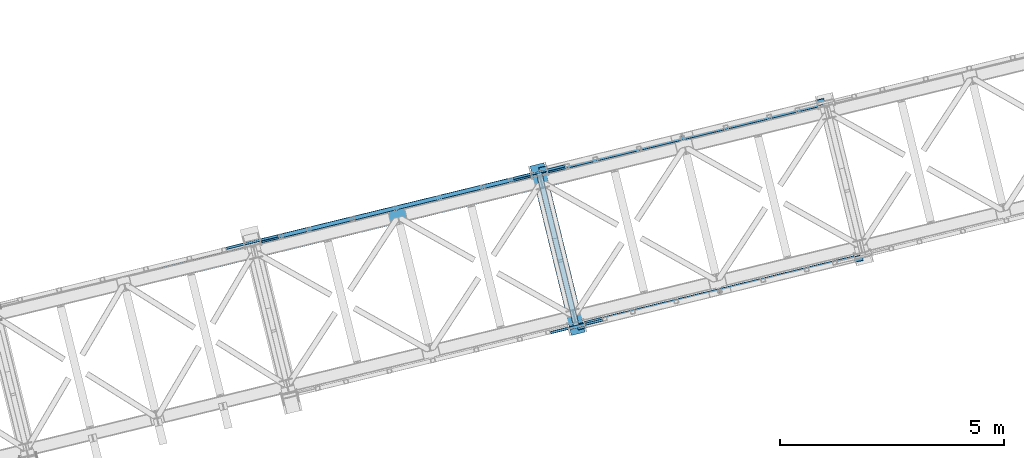
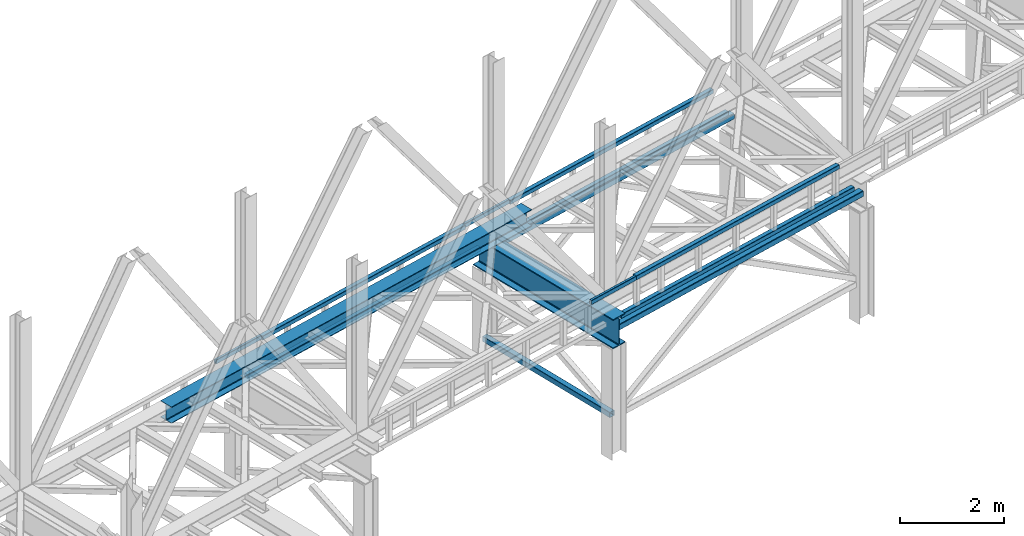
# One storey, part 16 of 93: 11 beams, 3 members.
"""IFC4 building model written with IfcOpenShell, lengths in millimetres."""

from ifc_helpers import new_model, entity, si_unit, converted_unit, derived_unit, direction, frame, origin, place, context, subcontext, project, spatial, indexed_curve, outline, extrude, material, type_object, element, save


model = new_model("IFC4")

# Units and contexts
model_context = context("Model", 3, precision=0.01, world=origin(), true_north=direction((6.12303176911189e-17, 1.0)))
plan_context = context("Plan", 3, precision=0.01, world=origin(), true_north=direction((6.12303176911189e-17, 1.0)))
body_context = subcontext(model_context, "Body", "Model", "MODEL_VIEW")
ifc_project = project(units=[si_unit("LENGTHUNIT", "METRE", prefix="MILLI"), si_unit("AREAUNIT", "SQUARE_METRE"), si_unit("VOLUMEUNIT", "CUBIC_METRE"), converted_unit("PLANEANGLEUNIT", "DEGREE", entity("IfcRatioMeasure", 0.0174532925199433), si_unit("PLANEANGLEUNIT", "RADIAN"), dimensions=[0, 0, 0, 0, 0, 0, 0]), si_unit("MASSUNIT", "GRAM", prefix="KILO"), derived_unit("MASSDENSITYUNIT", [(si_unit("MASSUNIT", "GRAM", prefix="KILO"), 1), (si_unit("LENGTHUNIT", "METRE"), -3)]), derived_unit("MOMENTOFINERTIAUNIT", [(si_unit("LENGTHUNIT", "METRE"), 4)]), si_unit("TIMEUNIT", "SECOND"), si_unit("FREQUENCYUNIT", "HERTZ"), si_unit("THERMODYNAMICTEMPERATUREUNIT", "DEGREE_CELSIUS"), derived_unit("THERMALTRANSMITTANCEUNIT", [(si_unit("MASSUNIT", "GRAM", prefix="KILO"), 1), (si_unit("THERMODYNAMICTEMPERATUREUNIT", "KELVIN"), -1), (si_unit("TIMEUNIT", "SECOND"), -3)]), derived_unit("VOLUMETRICFLOWRATEUNIT", [(si_unit("LENGTHUNIT", "METRE"), 3), (si_unit("TIMEUNIT", "SECOND"), -1)]), derived_unit("MASSFLOWRATEUNIT", [(si_unit("MASSUNIT", "GRAM", prefix="KILO"), 1), (si_unit("TIMEUNIT", "SECOND"), -1)]), derived_unit("ROTATIONALFREQUENCYUNIT", [(si_unit("TIMEUNIT", "SECOND"), -1)]), si_unit("ELECTRICCURRENTUNIT", "AMPERE"), si_unit("ELECTRICVOLTAGEUNIT", "VOLT"), si_unit("POWERUNIT", "WATT"), si_unit("FORCEUNIT", "NEWTON", prefix="KILO"), si_unit("ILLUMINANCEUNIT", "LUX"), si_unit("LUMINOUSFLUXUNIT", "LUMEN"), si_unit("LUMINOUSINTENSITYUNIT", "CANDELA"), derived_unit("USERDEFINED", [(si_unit("MASSUNIT", "GRAM", prefix="KILO"), -1), (si_unit("LENGTHUNIT", "METRE"), -2), (si_unit("TIMEUNIT", "SECOND"), 3), (si_unit("LUMINOUSFLUXUNIT", "LUMEN"), 1)]), derived_unit("LINEARVELOCITYUNIT", [(si_unit("LENGTHUNIT", "METRE"), 1), (si_unit("TIMEUNIT", "SECOND"), -1)]), si_unit("PRESSUREUNIT", "PASCAL"), derived_unit("USERDEFINED", [(si_unit("LENGTHUNIT", "METRE"), -2), (si_unit("MASSUNIT", "GRAM", prefix="KILO"), 1), (si_unit("TIMEUNIT", "SECOND"), -2)]), derived_unit("LINEARFORCEUNIT", [(si_unit("MASSUNIT", "GRAM", prefix="KILO"), 1), (si_unit("LENGTHUNIT", "METRE"), 1), (si_unit("TIMEUNIT", "SECOND"), -2), (si_unit("LENGTHUNIT", "METRE"), -1)]), derived_unit("PLANARFORCEUNIT", [(si_unit("MASSUNIT", "GRAM", prefix="KILO"), 1), (si_unit("LENGTHUNIT", "METRE"), 1), (si_unit("TIMEUNIT", "SECOND"), -2), (si_unit("LENGTHUNIT", "METRE"), -2)])], contexts=[model_context, plan_context])

# Site, building, storey
site_placement = place(None, origin())
site = spatial("IfcSite", under=ifc_project, at=site_placement, CompositionType="ELEMENT")
building_placement = place(site_placement, origin())
building = spatial("IfcBuilding", under=site, at=building_placement, CompositionType="ELEMENT")
storey_placement = place(building_placement, frame((0.0, 0.0, 15900.0)))
storey = spatial("IfcBuildingStorey", under=building, at=storey_placement, CompositionType="ELEMENT", Elevation=15900.0)

# Beams
ifc_material = material(Name="Metal painted (White)")
beam_type = type_object("IfcBeamType", PredefinedType="BEAM")
beam_1_placement = place(storey_placement, origin())
element("IfcBeam", 1, at=beam_1_placement, inside=storey, type_object=beam_type, material=ifc_material, ObjectType="Steel Beam", PredefinedType="BEAM", context=body_context, shape_type="SweptSolid", body=[
    extrude(outline(indexed_curve([(-345.500000000002, -159.999999999984), (-322.5, -159.999999999984), (-322.5, -37.4999999999816), (-320.216385975338, -26.0194970290252), (-313.713203435595, -16.2867965643877), (-303.980502970953, -9.78361402464055), (-292.499999999998, -7.49999999997847), (292.500000000001, -7.49999999997847), (303.980502970953, -9.78361402464055), (313.713203435597, -16.2867965643877), (320.21638597534, -26.0194970290252), (322.5, -37.4999999999816), (322.5, -159.999999999984), (345.499999999997, -159.999999999984), (345.499999999997, 160.00000000002), (322.5, 160.00000000002), (322.5, 37.5000000000174), (320.21638597534, 26.0194970290696), (313.713203435597, 16.2867965644235), (303.980502970953, 9.78361402467601), (292.500000000001, 7.50000000002312), (-292.499999999998, 7.50000000002312), (-303.980502970953, 9.78361402468494), (-313.713203435595, 16.2867965644235), (-320.216385975338, 26.0194970290607), (-322.5, 37.5000000000174), (-322.5, 160.000000000019), (-345.500000000002, 160.00000000002), (-345.500000000002, -159.999999999984)], self_intersect=False)), frame((-42110.0450911506, 6925.09563756373, 2947.5), z_axis=(-0.236826092990338, 0.971552058141473, 0.0), x_axis=(0.0, 0.0, 1.0)), (0.0, 0.0, 1.0), 3899.99999999999),
])
beam_2_placement = place(storey_placement, origin())
element("IfcBeam", 2, at=beam_2_placement, inside=storey, type_object=beam_type, material=ifc_material, ObjectType="Steel Beam", PredefinedType="BEAM", context=body_context, shape_type="SweptSolid", body=[
    extrude(outline(indexed_curve([(-195.999999999999, -150.000000000006), (-179.999999999996, -150.000000000006), (-179.999999999996, -27.7500000000052), (-178.325349715245, -19.3309644879713), (-173.556349186101, -12.1936508139007), (-166.419035512029, -7.42465028475701), (-157.999999999997, -5.75000000000425), (158.000000000005, -5.75000000000425), (166.419035512033, -7.42465028475701), (173.556349186107, -12.1936508139007), (178.325349715251, -19.3309644879713), (180.0, -27.7500000000052), (180.0, -150.000000000006), (196.000000000005, -150.000000000006), (196.000000000005, 149.999999999997), (180.0, 149.999999999997), (180.0, 27.7499999999967), (178.325349715251, 19.3309644879618), (173.556349186107, 12.1936508138912), (166.419035512033, 7.4246502847486), (158.000000000005, 5.74999999999479), (-157.999999999997, 5.74999999999584), (-166.419035512029, 7.42465028474754), (-173.556349186101, 12.1936508138923), (-178.325349715247, 19.3309644879639), (-179.999999999996, 27.7499999999988), (-179.999999999996, 149.999999999998), (-195.999999999999, 149.999999999997), (-195.999999999999, -150.000000000006)], self_intersect=False)), frame((-51415.7281239011, 8259.22017971819, 3489.0), z_axis=(0.971552058141477, 0.23682609299032, 0.0), x_axis=(0.0, 0.0, 1.0)), (0.0, 0.0, 1.0), 9600.0),
])
beam_3_placement = place(storey_placement, origin())
element("IfcBeam", 3, at=beam_3_placement, inside=storey, type_object=beam_type, material=ifc_material, ObjectType="Steel Beam", PredefinedType="BEAM", context=body_context, shape_type="SweptSolid", body=[
    extrude(outline(indexed_curve([(29.4768951153018, -56.8428769008144), (33.3787015556258, -56.8428769008144), (36.9835006656596, -55.3497202198119), (39.7424944584905, -52.590726426981), (41.2356511394979, -48.9859273169476), (56.842876900814, 29.4768951153048), (56.8428769008189, 33.3787015556257), (55.3497202198128, 36.9835006656636), (52.590726426984, 39.7424944584929), (48.9859273169497, 41.2356511395006), (-29.4768951153031, 56.8428769008191), (-33.3787015556266, 56.8428769008212), (-36.9835006656618, 55.3497202198168), (-39.7424944584927, 52.5907264269859), (-41.2356511395002, 48.9859273169525), (-56.8428769008193, -29.4768951152993), (-56.8428769008191, -33.3787015556212), (-55.3497202198151, -36.9835006656587), (-52.5907264269859, -39.742494458486), (-48.985927316952, -41.2356511394957), (29.4768951153018, -56.8428769008144)], self_intersect=False), holes=[indexed_curve([(-50.9634988887179, -25.5484203233677), (-37.3071763475653, 43.1065493048552), (-35.8140196665578, 46.7113484148885), (-33.0550258737248, 49.470342207719), (-29.4502267636906, 50.9634988887236), (-25.5484203233682, 50.9634988887217), (43.1065493048514, 37.3071763475684), (46.7113484148898, 35.8140196665599), (49.4703422077155, 33.0550258737312), (50.9634988887226, 29.450226763693), (50.9634988887228, 25.5484203233711), (37.3071763475682, -43.1065493048513), (35.8140196665566, -46.7113484148839), (33.0550258737271, -49.4703422077128), (29.4502267636909, -50.963498888717), (25.5484203233684, -50.9634988887151), (-43.1065493048507, -37.3071763475597), (-46.711348414886, -35.8140196665518), (-49.4703422077108, -33.0550258737233), (-50.9634988887187, -29.4502267636894), (-50.9634988887179, -25.5484203233677)], self_intersect=False)]), frame((-49204.2348073202, 9004.15125754903, 3118.0), z_axis=(0.971552058141251, 0.23682609299125, 0.0), x_axis=(-0.232275546020868, 0.952883957770417, 0.195090322016481)), (0.0, 0.0, 1.0), 6199.99999999998),
])
beam_4_placement = place(storey_placement, origin())
element("IfcBeam", 4, at=beam_4_placement, inside=storey, type_object=beam_type, material=ifc_material, ObjectType="Steel Beam", PredefinedType="BEAM", context=body_context, shape_type="SweptSolid", body=[
    extrude(outline(indexed_curve([(29.4768951153029, -56.8428769008146), (33.3787015556268, -56.8428769008146), (36.9835006656606, -55.3497202198121), (39.7424944584956, -52.590726426982), (41.235651139502, -48.9859273169485), (56.8428769008191, 29.4768951153038), (56.842876900822, 33.378701555625), (55.3497202198149, 36.9835006656632), (52.5907264269871, 39.7424944584923), (48.9859273169518, 41.2356511395002), (-29.4768951153, 56.8428769008184), (-33.3787015556235, 56.8428769008206), (-36.9835006656577, 55.349720219816), (-39.7424944584866, 52.5907264269846), (-41.2356511394971, 48.9859273169519), (-56.8428769008121, -29.4768951153007), (-56.8428769008149, -33.378701555622), (-55.349720219812, -36.9835006656594), (-52.5907264269838, -39.7424944584864), (-48.9859273169489, -41.2356511394963), (29.4768951153029, -56.8428769008146)], self_intersect=False), holes=[indexed_curve([(-50.9634988887168, -25.5484203233679), (-37.3071763475642, 43.106549304855), (-35.8140196665578, 46.7113484148885), (-33.0550258737248, 49.470342207719), (-29.4502267636906, 50.9634988887236), (-25.5484203233671, 50.9634988887215), (43.1065493048524, 37.3071763475682), (46.7113484148898, 35.8140196665599), (49.4703422077155, 33.0550258737312), (50.9634988887247, 29.4502267636926), (50.9634988887239, 25.5484203233709), (37.3071763475671, -43.1065493048511), (35.8140196665587, -46.7113484148843), (33.0550258737282, -49.4703422077131), (29.4502267636919, -50.9634988887172), (25.5484203233684, -50.9634988887151), (-43.1065493048507, -37.3071763475597), (-46.7113484148819, -35.8140196665527), (-49.4703422077097, -33.0550258737235), (-50.9634988887176, -29.4502267636896), (-50.9634988887168, -25.5484203233679)], self_intersect=False)]), frame((-42791.9912235865, 10567.2034712852, 3118.0), z_axis=(0.971552058141251, 0.23682609299125, 0.0), x_axis=(-0.232275546020868, 0.952883957770417, 0.195090322016481)), (0.0, 0.0, 1.0), 6200.00000000001),
])
beam_5_placement = place(storey_placement, origin())
element("IfcBeam", 5, at=beam_5_placement, inside=storey, type_object=beam_type, material=ifc_material, ObjectType="Steel Beam", PredefinedType="BEAM", context=body_context, shape_type="SweptSolid", body=[
    extrude(outline(indexed_curve([(29.4768951153347, -56.8428769007943), (33.3787015556582, -56.8428769007943), (36.9835006656916, -55.3497202197878), (39.7424944585226, -52.5907264269579), (41.2356511395291, -48.9859273169239), (56.8428769008035, 29.4768951153368), (56.8428769008039, 33.378701555667), (55.3497202197956, 36.9835006656975), (52.5907264269664, 39.7424944585252), (48.985927316931, 41.2356511395353), (-29.4768951153292, 56.8428769008109), (-33.3787015556536, 56.8428769008067), (-36.983500665687, 55.3497202198001), (-39.7424944585192, 52.5907264269749), (-41.2356511395254, 48.985927316932), (-56.8428769007998, -29.4768951153287), (-56.8428769008005, -33.37870155565), (-55.349720219791, -36.9835006656852), (-52.5907264269618, -39.7424944585128), (-48.9859273169256, -41.2356511395187), (29.4768951153347, -56.8428769007943)], self_intersect=False), holes=[indexed_curve([(-50.9634988887049, -25.5484203233842), (-37.3071763475873, 43.1065493048368), (-35.8140196665807, 46.7113484148708), (-33.0550258737509, 49.4703422077053), (-29.4502267637155, 50.9634988887115), (-25.548420323394, 50.9634988887119), (43.106549304835, 37.3071763475954), (46.7113484148691, 35.81401966659), (49.4703422076963, 33.0550258737628), (50.9634988887049, 29.4502267637233), (50.9634988887063, 25.5484203234016), (37.3071763475907, -43.1065493048198), (35.8140196665866, -46.7113484148631), (33.0550258737555, -49.470342207693), (29.4502267637221, -50.9634988886995), (25.5484203233986, -50.9634988886995), (-43.1065493048304, -37.3071763475831), (-46.7113484148624, -35.814019666578), (-49.4703422076938, -33.05502587375), (-50.9634988887032, -29.4502267637148), (-50.9634988887049, -25.5484203233842)], self_intersect=False)]), frame((-42403.3704003299, 10661.9339084814, 3830.0), z_axis=(0.971552058141251, 0.23682609299125, 0.0), x_axis=(0.232275546020893, -0.95288395777052, -0.195090322015947)), (0.0, 0.0, 1.0), 5399.99999999998),
])
beam_6_placement = place(storey_placement, origin())
element("IfcBeam", 6, at=beam_6_placement, inside=storey, type_object=beam_type, material=ifc_material, ObjectType="Steel Beam", PredefinedType="BEAM", context=body_context, shape_type="SweptSolid", body=[
    extrude(outline(indexed_curve([(29.4768951153316, -56.8428769007937), (33.3787015556551, -56.8428769007937), (36.9835006656885, -55.3497202197871), (39.7424944585144, -52.5907264269562), (41.2356511395209, -48.9859273169223), (56.8428769007963, 29.4768951153382), (56.8428769007977, 33.3787015556682), (55.3497202197915, 36.9835006656984), (52.5907264269612, 39.7424944585262), (48.9859273169269, 41.2356511395361), (-29.4768951153344, 56.8428769008119), (-33.3787015556587, 56.8428769008077), (-36.9835006656932, 55.3497202198013), (-39.7424944585223, 52.5907264269755), (-41.2356511395285, 48.9859273169326), (-56.8428769008049, -29.4768951153277), (-56.8428769008046, -33.3787015556492), (-55.3497202197962, -36.9835006656842), (-52.5907264269659, -39.742494458512), (-48.9859273169297, -41.2356511395179), (29.4768951153316, -56.8428769007937)], self_intersect=False), holes=[indexed_curve([(-50.963498888708, -25.5484203233836), (-37.3071763475914, 43.1065493048376), (-35.8140196665838, 46.7113484148714), (-33.055025873754, 49.4703422077059), (-29.4502267637186, 50.9634988887121), (-25.5484203233971, 50.9634988887125), (43.1065493048299, 37.3071763475965), (46.7113484148619, 35.8140196665914), (49.4703422076901, 33.055025873764), (50.9634988887039, 29.4502267637235), (50.9634988887052, 25.5484203234018), (37.3071763475896, -43.1065493048196), (35.8140196665804, -46.7113484148619), (33.0550258737504, -49.4703422076919), (29.450226763718, -50.9634988886987), (25.5484203233955, -50.9634988886989), (-43.1065493048325, -37.3071763475827), (-46.7113484148696, -35.8140196665766), (-49.470342207701, -33.0550258737486), (-50.9634988887063, -29.4502267637142), (-50.963498888708, -25.5484203233836)], self_intersect=False)]), frame((-48815.6139840636, 9098.88169474515, 3830.0), z_axis=(0.971552058141251, 0.23682609299125, 0.0), x_axis=(0.232275546020893, -0.95288395777052, -0.195090322015947)), (0.0, 0.0, 1.0), 5400.00000000001),
])
beam_7_placement = place(storey_placement, origin())
element("IfcBeam", 7, at=beam_7_placement, inside=storey, type_object=beam_type, material=ifc_material, ObjectType="Steel Beam", PredefinedType="BEAM", context=body_context, shape_type="SweptSolid", body=[
    extrude(outline(indexed_curve([(9.86118950715225, -52.9410704605097), (13.7629959474774, -52.9410704605097), (17.3677950575143, -51.4479137795155), (20.1267888503502, -48.6889199866869), (21.6199455313614, -45.0841208766556), (37.2271712928088, 33.3787015555707), (37.227171292818, 37.280507995892), (35.7340146118185, 40.8853071059301), (32.9750208189942, 43.6443008987639), (29.3702217089621, 45.1374575797819), (-9.86118950715206, 52.9410704605053), (-13.7629959474754, 52.9410704605093), (-17.367795057512, 51.4479137795106), (-20.1267888503471, 48.6889199866863), (-21.6199455313584, 45.084120876655), (-37.2271712928057, -33.3787015555713), (-37.2271712928159, -37.2805079958924), (-35.7340146118152, -40.8853071059351), (-32.9750208189911, -43.6443008987645), (-29.3702217089609, -45.1374575797865), (9.86118950715225, -52.9410704605097)], self_intersect=False), holes=[indexed_curve([(-31.347793280702, -29.4502267636485), (-17.6914707394371, 39.204742864552), (-16.1983140584197, 42.8095419745821), (-13.4393202655878, 45.568535767407), (-9.834521155548, 47.0616924484051), (-5.93271471522451, 47.0616924483966), (23.4908436968575, 41.2089827878548), (27.0956428068904, 39.7158261068411), (29.8546365997147, 36.9568323140073), (31.3477932807163, 33.3520332039688), (31.3477932807071, 29.4502267636475), (17.6914707394423, -39.2047428645531), (16.1983140584279, -42.8095419745838), (13.43932026559, -45.5685357674119), (9.8345211555542, -47.0616924484064), (5.93271471523173, -47.0616924483981), (-23.4908436968513, -41.208982787856), (-27.0956428068832, -39.7158261068425), (-29.8546365997085, -36.9568323140085), (-31.3477932807081, -33.3520332039704), (-31.347793280702, -29.4502267636485)], self_intersect=False)]), frame((-49986.2129756932, 8834.12142431958, 3830.0), z_axis=(0.971552058141243, 0.236826092991282, 0.0), x_axis=(-0.232275546020792, 0.952883957770107, 0.195090322018083)), (0.0, 0.0, 1.0), 1200.0),
])
beam_8_placement = place(storey_placement, origin())
element("IfcBeam", 8, at=beam_8_placement, inside=storey, type_object=beam_type, material=ifc_material, ObjectType="Steel Beam", PredefinedType="BEAM", context=body_context, shape_type="SweptSolid", body=[
    extrude(outline(indexed_curve([(9.86118950715024, -52.9410704605093), (13.7629959474754, -52.9410704605093), (17.3677950575112, -51.4479137795149), (20.1267888503492, -48.6889199866867), (21.6199455313614, -45.0841208766556), (37.2271712928046, 33.3787015555715), (37.227171292818, 37.280507995892), (35.7340146118163, 40.8853071059305), (32.9750208189931, 43.6443008987641), (29.370221708961, 45.1374575797821), (-9.86118950715314, 52.9410704605055), (-13.7629959474754, 52.9410704605093), (-17.3677950575141, 51.447913779511), (-20.1267888503492, 48.6889199866867), (-21.6199455313635, 45.084120876656), (-37.2271712928087, -33.3787015555707), (-37.227171292818, -37.280507995892), (-35.7340146118193, -40.8853071059343), (-32.9750208189931, -43.6443008987641), (-29.3702217089639, -45.1374575797859), (9.86118950715024, -52.9410704605093)], self_intersect=False), holes=[indexed_curve([(-31.3477932807029, -29.4502267636483), (-17.6914707394361, 39.2047428645519), (-16.1983140584218, 42.8095419745826), (-13.4393202655909, 45.5685357674077), (-9.83452115555012, 47.0616924484056), (-5.93271471522662, 47.0616924483971), (23.4908436968565, 41.208982787855), (27.0956428068852, 39.7158261068421), (29.8546365997126, 36.9568323140076), (31.3477932807142, 33.3520332039692), (31.3477932807071, 29.4502267636475), (17.6914707394403, -39.2047428645527), (16.1983140584259, -42.8095419745834), (13.439320265588, -45.5685357674115), (9.83452115555012, -47.0616924484056), (5.93271471523075, -47.0616924483979), (-23.4908436968565, -41.208982787855), (-27.0956428068832, -39.7158261068425), (-29.8546365997085, -36.9568323140085), (-31.3477932807101, -33.35203320397), (-31.3477932807029, -29.4502267636483)], self_intersect=False)]), frame((-43573.9693919595, 10397.1736380558, 3830.0), z_axis=(0.971552058141251, 0.23682609299125, 0.0), x_axis=(-0.232275546020792, 0.952883957770107, 0.195090322018083)), (0.0, 0.0, 1.0), 1199.99999999999),
])
beam_9_placement = place(storey_placement, origin())
element("IfcBeam", 9, at=beam_9_placement, inside=storey, type_object=beam_type, material=ifc_material, ObjectType="Steel Beam", PredefinedType="BEAM", context=body_context, shape_type="SweptSolid", body=[
    extrude(outline(indexed_curve([(29.4768951153303, -56.8428769008022), (33.3787015556528, -56.8428769008022), (36.9835006656877, -55.3497202197939), (39.7424944585154, -52.5907264269657), (41.2356511395221, -48.9859273169318), (56.8428769008018, 29.4768951153279), (56.8428769008011, 33.3787015556517), (55.3497202197953, 36.9835006656885), (52.5907264269647, 39.7424944585144), (48.9859273169307, 41.23565113952), (-29.4768951153307, 56.8428769008001), (-33.3787015556532, 56.8428769008001), (-36.9835006656873, 55.349720219796), (-39.7424944585158, 52.5907264269635), (-41.2356511395229, 48.9859273169275), (-56.8428769008026, -29.4768951153321), (-56.8428769008015, -33.3787015556538), (-55.3497202197949, -36.9835006656864), (-52.5907264269652, -39.7424944585165), (-48.9859273169312, -41.2356511395222), (29.4768951153303, -56.8428769008022)], self_intersect=False), holes=[indexed_curve([(-50.9634988887073, -25.5484203233968), (-37.3071763475893, 43.1065493048329), (-35.8140196665836, 46.711348414867), (-33.055025873752, 49.4703422076989), (-29.450226763717, 50.9634988887072), (-25.5484203233935, 50.963498888707), (43.1065493048327, 37.3071763475875), (46.7113484148708, 35.814019666581), (49.4703422077005, 33.0550258737509), (50.9634988887053, 29.4502267637143), (50.9634988887054, 25.5484203233928), (37.3071763475853, -43.1065493048366), (35.8140196665786, -46.7113484148704), (33.0550258737495, -49.4703422077006), (29.4502267637154, -50.9634988887046), (25.5484203233919, -50.9634988887045), (-43.1065493048333, -37.3071763475851), (-46.7113484148703, -35.8140196665789), (-49.4703422076995, -33.0550258737511), (-50.9634988887071, -29.4502267637183), (-50.9634988887073, -25.5484203233968)], self_intersect=False)]), frame((-41960.9684632834, 7158.02729926682, 3118.0), z_axis=(0.97155205814122, 0.236826092991375, 0.0), x_axis=(-0.232275546020954, 0.952883957770495, 0.195090322015999)), (0.0, 0.0, 1.0), 6200.00000000002),
])
beam_10_placement = place(storey_placement, origin())
element("IfcBeam", 10, at=beam_10_placement, inside=storey, type_object=beam_type, material=ifc_material, ObjectType="Steel Beam", PredefinedType="BEAM", context=body_context, shape_type="SweptSolid", body=[
    extrude(outline(indexed_curve([(29.4768951153305, -56.8428769007956), (33.378701555653, -56.8428769007956), (36.9835006656875, -55.3497202197894), (39.7424944585167, -52.5907264269593), (41.2356511395223, -48.9859273169252), (56.842876900802, 29.4768951153345), (56.8428769008026, 33.3787015556647), (55.3497202197956, 36.9835006656951), (52.5907264269654, 39.7424944585231), (48.9859273169322, 41.235651139533), (-29.4768951153282, 56.8428769008128), (-33.3787015556525, 56.8428769008088), (-36.9835006656871, 55.3497202198026), (-39.7424944585143, 52.5907264269765), (-41.2356511395227, 48.9859273169341), (-56.8428769008024, -29.4768951153256), (-56.8428769008013, -33.3787015556473), (-55.3497202197951, -36.9835006656819), (-52.5907264269649, -39.7424944585099), (-48.9859273169299, -41.2356511395158), (29.4768951153305, -56.8428769007956)], self_intersect=False), holes=[indexed_curve([(-50.9634988887053, -25.5484203233818), (-37.3071763475859, 43.1065493048389), (-35.8140196665772, 46.7113484148724), (-33.0550258737482, 49.470342207707), (-29.4502267637158, 50.9634988887136), (-25.5484203233933, 50.9634988887136), (43.1065493048319, 37.3071763475942), (46.71134841487, 35.8140196665878), (49.470342207696, 33.0550258737606), (50.9634988887045, 29.4502267637211), (50.9634988887056, 25.5484203233994), (37.3071763475893, -43.1065493048219), (35.8140196665799, -46.7113484148641), (33.0550258737508, -49.4703422076942), (29.4502267637152, -50.9634988887002), (25.5484203233927, -50.9634988887002), (-43.1065493048345, -37.3071763475805), (-46.7113484148685, -35.8140196665748), (-49.4703422076976, -33.055025873747), (-50.9634988887048, -29.4502267637122), (-50.9634988887053, -25.5484203233818)], self_intersect=False)]), frame((-41572.3476400268, 7252.75773646296, 3830.0), z_axis=(0.97155205814122, 0.236826092991375, 0.0), x_axis=(0.232275546020954, -0.952883957770495, -0.195090322015999)), (0.0, 0.0, 1.0), 5399.99999999998),
])
beam_11_placement = place(storey_placement, origin())
element("IfcBeam", 11, at=beam_11_placement, inside=storey, type_object=beam_type, material=ifc_material, ObjectType="Steel Beam", PredefinedType="BEAM", context=body_context, shape_type="SweptSolid", body=[
    extrude(outline(indexed_curve([(9.86118950714837, -52.94107046051), (13.7629959474725, -52.94107046051), (17.3677950575095, -51.447913779516), (20.1267888503455, -48.6889199866876), (21.619945531358, -45.0841208766565), (37.2271712928105, 33.3787015555687), (37.2271712928189, 37.2805079958902), (35.7340146118196, 40.8853071059284), (32.9750208189954, 43.6443008987624), (29.3702217089645, 45.1374575797803), (-9.86118950714922, 52.9410704605058), (-13.7629959474725, 52.94107046051), (-17.3677950575103, 51.4479137795117), (-20.1267888503455, 48.6889199866876), (-21.619945531358, 45.0841208766565), (-37.2271712928105, -33.3787015555687), (-37.2271712928189, -37.2805079958902), (-35.7340146118204, -40.8853071059326), (-32.9750208189954, -43.6443008987624), (-29.3702217089653, -45.1374575797846), (9.86118950714837, -52.94107046051)], self_intersect=False), holes=[indexed_curve([(-31.3477932807035, -29.4502267636469), (-17.691470739433, 39.2047428645526), (-16.1983140584174, 42.809541974583), (-13.4393202655874, 45.5685357674081), (-9.83452115554754, 47.0616924484061), (-5.93271471522507, 47.0616924483976), (23.4908436968607, 41.2089827878534), (27.0956428068884, 39.7158261068405), (29.8546365997146, 36.9568323140061), (31.347793280715, 33.3520332039677), (31.3477932807076, 29.450226763646), (17.6914707394371, -39.2047428645534), (16.1983140584215, -42.8095419745838), (13.4393202655865, -45.5685357674124), (9.8345211555496, -47.0616924484065), (5.93271471522817, -47.0616924483982), (-23.4908436968576, -41.208982787854), (-27.0956428068853, -39.7158261068411), (-29.8546365997082, -36.9568323140118), (-31.3477932807109, -33.3520332039686), (-31.3477932807035, -29.4502267636469)], self_intersect=False)]), frame((-42733.4735879368, 6949.13538371172, 3830.0), z_axis=(0.97155205814122, 0.236826092991375, 0.0), x_axis=(-0.232275546020854, 0.952883957770082, 0.195090322018134)), (0.0, 0.0, 1.0), 1199.99999999999),
])

# Members
member_type_1 = type_object("IfcMemberType", PredefinedType="BRACE")
member_1_placement = place(storey_placement, origin())
element("IfcMember", 12, at=member_1_placement, inside=storey, type_object=member_type_1, ObjectType="Steel Vertical Brace", PredefinedType="BRACE", context=body_context, shape_type="SweptSolid", body=[
    extrude(outline(indexed_curve([(41.2596526560579, -71.9315025750194), (44.3810978083225, -71.9315025750194), (47.2649370963498, -70.7369772302093), (49.4721321306099, -68.5297821959409), (50.6666574754114, -65.6459429079105), (71.9315025750208, 41.2596526560702), (71.9315025750162, 44.3810978083293), (70.7369772302065, 47.2649370963526), (68.5297821959393, 49.4721321306162), (65.6459429079025, 50.6666574754182), (-41.2596526560747, 71.931502575025), (-44.3810978083313, 71.9315025750212), (-47.264937096359, 70.7369772302089), (-49.4721321306182, 68.5297821959448), (-50.6666574754197, 65.6459429079143), (-71.9315025750291, -41.2596526560663), (-71.9315025750246, -44.3810978083254), (-70.7369772302157, -47.264937096353), (-68.529782195948, -49.4721321306145), (-65.6459429079195, -50.6666574754126), (41.2596526560579, -71.9315025750194)], self_intersect=False), holes=[indexed_curve([(-67.228000165357, -38.1168728225121), (-47.5238776418647, 60.9424404982423), (-46.3293522970628, 63.8262797862748), (-44.1221572628033, 66.0334748205389), (-41.2383179747765, 67.2280001653469), (-38.1168728225197, 67.2280001653529), (60.9424404982391, 47.5238776418622), (63.8262797862667, 46.3293522970598), (66.0334748205344, 44.1221572627983), (67.2280001653441, 41.238317974775), (67.2280001653487, 38.1168728225159), (47.5238776418564, -60.9424404982384), (46.3293522970461, -63.8262797862671), (44.122157262786, -66.0334748205354), (41.2383179747684, -67.2280001653431), (38.1168728225029, -67.2280001653473), (-60.9424404982471, -47.5238776418584), (-63.826279786275, -46.329352297056), (-66.0334748205436, -44.1221572627987), (-67.2280001653524, -41.2383179747711), (-67.228000165357, -38.1168728225121)], self_intersect=False)]), frame((-42157.0424580588, 7117.89697955429, 898.0), z_axis=(-0.236826092990098, 0.971552058141532, 0.0), x_axis=(-0.952883957770956, -0.232275546020111, 0.195090322014749)), (0.0, 0.0, 1.0), 3545.80325659093),
])
member_type_2 = type_object("IfcMemberType", PredefinedType="BRACE")
member_2_placement = place(storey_placement, origin())
element("IfcMember", 13, at=member_2_placement, inside=storey, type_object=member_type_2, ObjectType="Steel Vertical Brace", PredefinedType="BRACE", context=body_context, shape_type="SweptSolid", body=[
    extrude(outline(indexed_curve([(37.8349046800508, -78.8972115340725), (44.6630659506159, -78.8972115340725), (50.971464393175, -76.2841873423058), (55.7997035306284, -71.4559482048567), (58.4127277223887, -65.1475497622927), (78.897211534066, 37.8349046800475), (78.8972115340659, 44.66306595061), (76.2841873423012, 50.9714643931725), (71.4559482048499, 55.7997035306222), (65.1475497622896, 58.4127277223865), (-37.8349046800525, 78.897211534064), (-44.6630659506184, 78.8972115340597), (-50.9714643931777, 76.2841873422975), (-55.7997035306309, 71.455948204844), (-58.4127277223904, 65.1475497622842), (-78.8972115340677, -37.834904680056), (-78.8972115340684, -44.6630659506228), (-76.284187342304, -50.9714643931808), (-71.4559482048524, -55.7997035306349), (-65.1475497622912, -58.412727722395), (37.8349046800508, -78.8972115340725)], self_intersect=False), holes=[indexed_curve([(-56.9164205453576, -52.9128630136832), (-63.2248189879183, -50.299838821921), (-68.0530581253707, -45.4715996844711), (-70.6660823171321, -39.1632012419137), (-70.6660823171344, -32.3350399713463), (-52.9128630136808, 56.9164205453492), (-50.2998388219219, 63.2248189879113), (-45.4715996844677, 68.0530581253646), (-39.1632012419078, 70.6660823171245), (-32.3350399713429, 70.666082317129), (56.9164205453538, 52.9128630136751), (63.2248189879131, 50.299838821911), (68.053058125369, 45.4715996844626), (70.6660823171295, 39.163201241901), (70.6660823171313, 32.3350399713359), (52.9128630136777, -56.9164205453596), (50.2998388219142, -63.224818987923), (45.4715996844625, -68.0530581253746), (39.1632012419036, -70.6660823171348), (32.3350399713391, -70.6660823171371), (-56.9164205453576, -52.9128630136832)], self_intersect=False)]), frame((-42128.5668661378, 7074.97299339512, 2948.00759027898), z_axis=(0.971552058141313, 0.236826092990994, 0.0), x_axis=(-0.232275546020611, 0.952883957770583, 0.195090322015976)), (0.0, 0.0, 1.0), 6564.99999999999),
])
member_type_3 = type_object("IfcMemberType", PredefinedType="BRACE")
member_3_placement = place(storey_placement, origin())
element("IfcMember", 14, at=member_3_placement, inside=storey, type_object=member_type_3, ObjectType="Steel Vertical Brace", PredefinedType="BRACE", context=body_context, shape_type="SweptSolid", body=[
    extrude(outline(indexed_curve([(37.8349046800522, -78.8972115340712), (44.6630659506184, -78.8972115340712), (50.9714643931763, -76.2841873423041), (55.7997035306285, -71.4559482048547), (58.4127277223887, -65.1475497622906), (78.8972115340617, 37.8349046800504), (78.8972115340614, 44.663065950613), (76.2841873422986, 50.971464393175), (71.4559482048471, 55.7997035306245), (65.1475497622867, 58.4127277223886), (-37.834904680056, 78.8972115340631), (-44.6630659506209, 78.8972115340584), (-50.9714643931801, 76.284187342296), (-55.7997035306331, 71.4559482048423), (-58.4127277223925, 65.1475497622825), (-78.8972115340675, -37.8349046800581), (-78.897211534066, -44.6630659506253), (-76.2841873423024, -50.9714643931831), (-71.4559482048517, -55.7997035306368), (-65.1475497622905, -58.4127277223967), (37.8349046800522, -78.8972115340712)], self_intersect=False), holes=[indexed_curve([(-56.916420545358, -52.9128630136845), (-63.2248189879188, -50.2998388219225), (-68.0530581253703, -45.471599684473), (-70.6660823171319, -39.1632012419157), (-70.6660823171375, -32.3350399713476), (-52.9128630136836, 56.9164205453479), (-50.299838821926, 63.2248189879102), (-45.4715996844729, 68.0530581253639), (-39.163201241912, 70.6660823171238), (-32.3350399713492, 70.6660823171289), (56.9164205453481, 52.9128630136776), (63.2248189879109, 50.2998388219152), (68.0530581253645, 45.4715996844653), (70.6660823171253, 39.1632012419037), (70.6660823171252, 32.335039971339), (52.9128630136794, -56.9164205453581), (50.2998388219131, -63.2248189879209), (45.4715996844666, -68.0530581253737), (39.1632012419038, -70.6660823171332), (32.3350399713372, -70.6660823171353), (-56.916420545358, -52.9128630136845)], self_intersect=False)]), frame((-42981.140800903, 10572.5604027044, 2948.00759027898), z_axis=(0.97155205814133, 0.236826092990923, 0.0), x_axis=(-0.232275546020575, 0.952883957770598, 0.195090322015947)), (0.0, 0.0, 1.0), 6564.99999999999),
])

save(model, "model.ifc")
